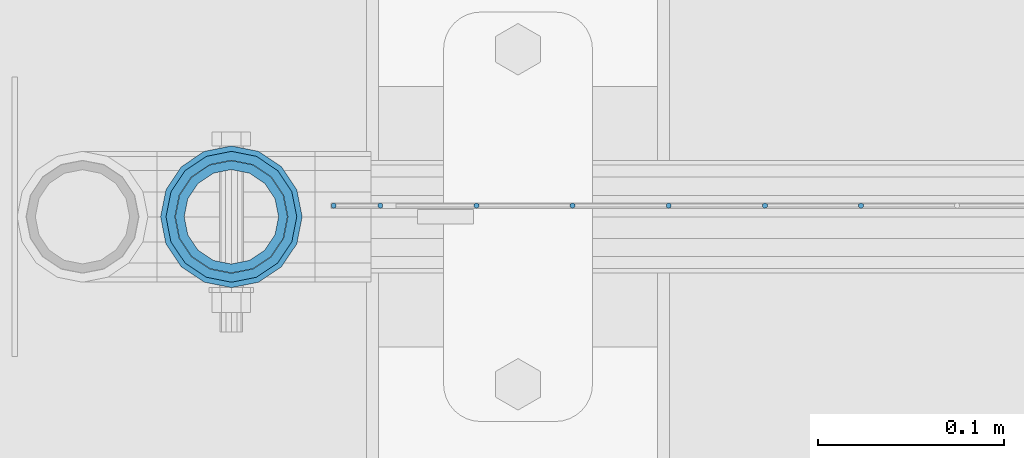
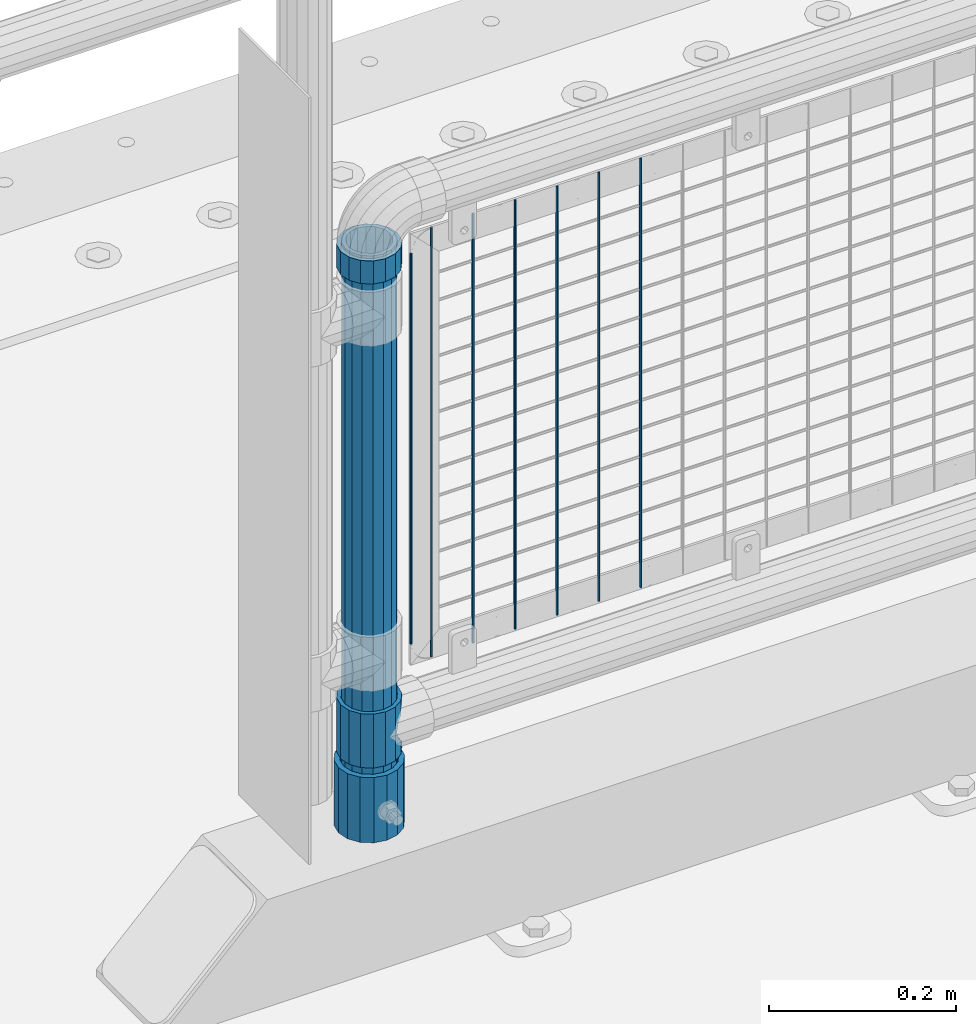
# One storey, part 52 of 193: 11 columns.
"""IFC2X3 building model written with IfcOpenShell, lengths in millimetres."""

from ifc_helpers import new_model, si_unit, frame, origin_with_axes, place, context, subcontext, project, spatial, faceted_brep, material, type_object, element, save


model = new_model("IFC2X3")

# Units and contexts
model_context = context("Model", 3, precision=1e-05, world=origin_with_axes())
body_context = subcontext(model_context, "Body", "Model", "MODEL_VIEW")
ifc_project = project(units=[si_unit("LENGTHUNIT", "METRE", prefix="MILLI"), si_unit("AREAUNIT", "SQUARE_METRE"), si_unit("VOLUMEUNIT", "CUBIC_METRE"), si_unit("MASSUNIT", "GRAM", prefix="KILO"), si_unit("TIMEUNIT", "SECOND"), si_unit("PLANEANGLEUNIT", "RADIAN"), si_unit("SOLIDANGLEUNIT", "STERADIAN"), si_unit("THERMODYNAMICTEMPERATUREUNIT", "DEGREE_CELSIUS"), si_unit("LUMINOUSINTENSITYUNIT", "LUMEN")], contexts=[model_context])

# Site, building, storey
site_placement = place(None, origin_with_axes())
site = spatial("IfcSite", under=ifc_project, at=site_placement, CompositionType="ELEMENT")
building_placement = place(site_placement, origin_with_axes())
building = spatial("IfcBuilding", under=site, at=building_placement, Name="Standard", CompositionType="ELEMENT")
storey_placement = place(building_placement, origin_with_axes())
storey = spatial("IfcBuildingStorey", under=building, at=storey_placement, Name="Undefined", CompositionType="ELEMENT", Elevation=0.0)

# Columns
ifc_material_1 = material(Name="Misc_Undefined")
column_type_1 = type_object("IfcColumnType", PredefinedType="NOTDEFINED")
column_1_placement = place(storey_placement, frame((-41829.0, 28664.5, 263.52), z_axis=(-1.0, 0.0, 0.0), x_axis=(0.0, 0.0, 1.0)))
element("IfcColumn", 1, at=column_1_placement, inside=storey, type_object=column_type_1, material=ifc_material_1, context=body_context, shape_type="Brep", body=[
    faceted_brep([(56.6106908090114, 21.46069080901, -21.46069080901), (56.6106908090114, 21.46069080901, -27.1226768591041), (61.9623795176744, 13.4513226476338, -32.4743655677703), (63.1897438117172, 11.614442172282, -32.8397438117245), (63.1897438117172, 11.614442172282, -28.0397438117179), (46.7644421722801, 28.0397438117179, -11.614442172282), (46.7644421722801, 28.0397438117179, -20.0882031229849), (51.5310424080006, 24.8548033587067, -24.8548033587067), (35.1500000000015, 30.35, 0.0), (35.1499999999996, 30.3499999999985, -16.6306603983685), (23.5355578277192, 28.0397438117179, -11.614442172282), (23.5355578277192, 28.0397438117179, -20.0882031229849), (13.6893091909879, 21.46069080901, -21.46069080901), (13.6893091909879, 21.46069080901, -27.1226768591041), (18.7689575919987, 24.8548033587067, -24.8548033587067), (7.11025618828211, 11.614442172282, -28.0397438117179), (7.11025618828211, 11.614442172282, -32.8397438117245), (8.33762048232262, 13.4513226476338, -32.4743655677703), (4.79999999999961, 0.0, -30.3499999999985), (4.79999999999961, 0.0, -35.1500000000015), (7.11025618828211, -11.614442172282, -28.0397438117179), (7.11025618828211, -11.614442172282, -32.8397438117172), (13.6893091909879, -21.46069080901, -21.46069080901), (13.6893091909879, -21.46069080901, -27.1226768591114), (8.33762048232484, -13.4513226476338, -32.4743655677703), (23.5355578277191, -28.0397438117179, -11.614442172282), (23.5355578277191, -28.0397438117179, -20.0882031229812), (18.7689575919921, -24.8548033587067, -24.8548033587067), (35.1500000000015, -30.35, 0.0), (35.1499999999996, -30.3499999999985, -16.6306603983721), (46.7644421722801, -28.0397438117179, -11.614442172282), (46.7644421722801, -28.0397438117179, -20.0882031229812), (56.6106908090114, -21.46069080901, -21.46069080901), (56.6106908090114, -21.46069080901, -27.1226768591114), (51.5310424080006, -24.8548033587067, -24.8548033587067), (63.1897438117172, -11.614442172282, -28.0397438117179), (63.1897438117172, -11.614442172282, -32.8397438117172), (61.9623795176767, -13.4513226476338, -32.4743655677703), (65.4999999999997, 0.0, -30.3499999999985), (65.4999999999997, 0.0, -35.1500000000015), (70.2999999999993, -11.614442172282, -28.0397438117179), (70.2999999999993, 0.0, -30.3499999999985), (70.2999999999993, -21.46069080901, -21.46069080901), (70.2999999999993, -28.0397438117179, -11.614442172282), (70.2999999999993, -30.3499999999985, 0.0), (0.0, -28.0397438117179, -11.614442172282), (0.0, -30.3499999999985, 0.0), (0.0, -21.46069080901, -21.46069080901), (0.0, -11.614442172282, -28.0397438117179), (0.0, 0.0, -30.3499999999985), (0.0, 11.614442172282, -28.0397438117179), (0.0, 21.46069080901, -21.46069080901), (0.0, 28.0397438117179, -11.614442172282), (0.0, 30.3499999999985, 0.0), (0.0, -24.8548033587067, -24.8548033587067), (0.0, -13.4513226476338, -32.4743655677703), (0.0, 0.0, -35.1500000000015), (0.0, 13.4513226476338, -32.4743655677703), (0.0, 24.8548033587067, -24.8548033587067), (0.0, -32.4743655677703, 13.4513226476338), (0.0, -35.1500000000015, 0.0), (70.2999999999993, -35.1500000000015, 0.0), (70.2999999999993, -32.4743655677703, 13.4513226476338), (0.0, -24.8548033587067, 24.8548033587067), (70.2999999999993, -24.8548033587067, 24.8548033587067), (0.0, -13.4513226476338, 32.4743655677703), (70.2999999999993, -13.4513226476338, 32.4743655677703), (0.0, 0.0, 35.1500000000015), (70.2999999999993, 0.0, 35.1500000000015), (0.0, 13.4513226476338, 32.4743655677703), (70.2999999999993, 13.4513226476338, 32.4743655677703), (0.0, 24.8548033587067, 24.8548033587067), (70.2999999999993, 24.8548033587067, 24.8548033587067), (0.0, 32.4743655677703, 13.4513226476338), (70.2999999999993, 32.4743655677703, 13.4513226476338), (0.0, 35.1500000000015, 0.0), (70.2999999999993, 35.1500000000015, 0.0), (0.0, 32.4743655677703, -13.4513226476338), (70.2999999999993, 32.4743655677703, -13.4513226476338), (70.2999999999993, 24.8548033587067, -24.8548033587067), (70.2999999999993, 13.4513226476338, -32.4743655677703), (70.2999999999993, 0.0, -35.1500000000015), (70.2999999999993, -13.4513226476338, -32.4743655677703), (70.2999999999993, -24.8548033587067, -24.8548033587067), (70.2999999999993, -32.4743655677703, -13.4513226476338), (0.0, -32.4743655677703, -13.4513226476338), (0.0, 28.0397438117179, 11.614442172282), (0.0, 21.46069080901, 21.46069080901), (0.0, 11.614442172282, 28.0397438117179), (0.0, 0.0, 30.3499999999985), (0.0, -11.614442172282, 28.0397438117179), (0.0, -21.46069080901, 21.46069080901), (0.0, -28.0397438117179, 11.614442172282), (70.2999999999993, 28.0397438117179, 11.614442172282), (70.2999999999993, 21.46069080901, 21.46069080901), (70.2999999999993, 11.614442172282, 28.0397438117179), (70.2999999999993, 0.0, 30.3499999999985), (70.2999999999993, -11.614442172282, 28.0397438117179), (70.2999999999993, -21.46069080901, 21.46069080901), (70.2999999999993, -28.0397438117179, 11.614442172282), (70.2999999999993, 30.3499999999985, 0.0), (70.2999999999993, 28.0397438117179, -11.614442172282), (70.2999999999993, 21.46069080901, -21.46069080901), (70.2999999999993, 11.614442172282, -28.0397438117179)], [[[0, 1, 2, 3, 4]], [[5, 6, 7, 1, 0]], [[8, 9, 6, 5]], [[10, 11, 9, 8]], [[12, 13, 14, 11, 10]], [[15, 16, 17, 13, 12]], [[18, 19, 16, 15]], [[20, 21, 19, 18]], [[22, 23, 24, 21, 20]], [[25, 26, 27, 23, 22]], [[28, 29, 26, 25]], [[30, 31, 29, 28]], [[32, 33, 34, 31, 30]], [[35, 36, 37, 33, 32]], [[38, 39, 36, 35]], [[4, 3, 39, 38]], [[40, 41, 38, 35]], [[42, 40, 35, 32]], [[43, 42, 32, 30]], [[44, 43, 30, 28]], [[45, 46, 28, 25]], [[47, 45, 25, 22]], [[48, 47, 22, 20]], [[49, 48, 20, 18]], [[50, 49, 18, 15]], [[51, 50, 15, 12]], [[52, 51, 12, 10]], [[53, 52, 10, 8]], [[54, 55, 24, 23, 27]], [[55, 56, 19, 21, 24]], [[19, 56, 57, 17, 16]], [[17, 57, 58, 14, 13]], [[59, 60, 61, 62]], [[63, 59, 62, 64]], [[65, 63, 64, 66]], [[67, 65, 66, 68]], [[69, 67, 68, 70]], [[71, 69, 70, 72]], [[73, 71, 72, 74]], [[75, 73, 74, 76]], [[77, 75, 76, 78]], [[14, 58, 77, 78, 79, 7, 6, 9, 11]], [[79, 80, 2, 1, 7]], [[80, 81, 39, 3, 2]], [[37, 82, 83, 34, 33]], [[39, 81, 82, 37, 36]], [[34, 83, 84, 85, 54, 27, 26, 29, 31]], [[60, 85, 84, 61]], [[59, 63, 65, 67, 69, 71, 73, 75, 77, 58, 57, 56, 55, 54, 85, 60], [45, 47, 48, 49, 50, 51, 52, 53, 86, 87, 88, 89, 90, 91, 92, 46]], [[87, 86, 93, 94]], [[88, 87, 94, 95]], [[89, 88, 95, 96]], [[90, 89, 96, 97]], [[91, 90, 97, 98]], [[92, 91, 98, 99]], [[28, 46, 92, 99, 44]], [[83, 82, 81, 80, 79, 78, 76, 74, 72, 70, 68, 66, 64, 62, 61, 84], [98, 97, 96, 95, 94, 93, 100, 101, 102, 103, 41, 40, 42, 43, 44, 99]], [[86, 53, 8, 100, 93]], [[101, 100, 8, 5]], [[102, 101, 5, 0]], [[103, 102, 0, 4]], [[41, 103, 4, 38]]]),
])
column_2_placement = place(storey_placement, frame((-41829.0, 28664.5, 894.849999999999), z_axis=(-1.0, 0.0, 0.0), x_axis=(0.0, 0.0, 1.0)))
element("IfcColumn", 2, at=column_2_placement, inside=storey, type_object=column_type_1, material=ifc_material_1, context=body_context, shape_type="Brep", body=[
    faceted_brep([(0.0, -30.3499999999985, 0.0), (0.0, -28.0397438117179, 11.614442172282), (30.0, -28.0397438117179, 11.6144421722805), (30.0, -30.3499999999985, 0.0), (0.0, -21.46069080901, 21.46069080901), (30.0, -21.46069080901, 21.4606908090117), (0.0, -11.614442172282, 28.0397438117179), (30.0, -11.614442172282, 28.0397438117176), (0.0, 0.0, 30.3499999999985), (30.0, 0.0, 30.35), (0.0, 11.614442172282, 28.0397438117179), (30.0, 11.614442172282, 28.0397438117176), (0.0, 21.46069080901, 21.46069080901), (30.0, 21.46069080901, 21.4606908090117), (0.0, 28.0397438117179, 11.614442172282), (30.0, 28.0397438117179, 11.6144421722805), (0.0, 30.3499999999985, 0.0), (30.0, 30.3499999999985, 0.0), (0.0, 28.0397438117179, -11.614442172282), (30.0, 28.0397438117179, -11.6144421722805), (0.0, 21.46069080901, -21.46069080901), (30.0, 21.46069080901, -21.4606908090117), (0.0, 11.614442172282, -28.0397438117179), (30.0, 11.614442172282, -28.0397438117176), (0.0, 0.0, -30.3499999999985), (30.0, 0.0, -30.35), (0.0, -11.614442172282, -28.0397438117179), (30.0, -11.614442172282, -28.0397438117176), (0.0, -21.46069080901, -21.46069080901), (30.0, -21.46069080901, -21.4606908090117), (0.0, -28.0397438117179, -11.614442172282), (30.0, -28.0397438117179, -11.6144421722805), (0.0, -35.1500000000015, 0.0), (0.0, -32.4743655677703, -13.4513226476338), (30.0, -32.4743655677703, -13.4513226476329), (30.0, -35.1500000000015, 0.0), (0.0, -24.8548033587067, -24.8548033587067), (30.0, -24.8548033587067, -24.8548033587072), (0.0, -13.4513226476338, -32.4743655677703), (30.0, -13.4513226476338, -32.4743655677718), (0.0, 0.0, -35.1500000000015), (30.0, 0.0, -35.15), (0.0, 13.4513226476338, -32.4743655677703), (30.0, 13.4513226476338, -32.4743655677718), (0.0, 24.8548033587067, -24.8548033587067), (30.0, 24.8548033587067, -24.8548033587072), (0.0, 32.4743655677703, -13.4513226476338), (30.0, 32.4743655677703, -13.4513226476329), (0.0, 35.1500000000015, 0.0), (30.0, 35.1500000000015, 0.0), (0.0, 32.4743655677703, 13.4513226476338), (30.0, 32.4743655677703, 13.4513226476329), (0.0, 24.8548033587067, 24.8548033587067), (30.0, 24.8548033587067, 24.8548033587072), (0.0, 13.4513226476338, 32.4743655677703), (30.0, 13.4513226476338, 32.4743655677718), (0.0, 0.0, 35.1500000000015), (30.0, 0.0, 35.15), (0.0, -13.4513226476338, 32.4743655677703), (30.0, -13.4513226476338, 32.4743655677718), (0.0, -24.8548033587067, 24.8548033587067), (30.0, -24.8548033587067, 24.8548033587072), (0.0, -32.4743655677703, 13.4513226476338), (30.0, -32.4743655677703, 13.4513226476329)], [[[0, 1, 2, 3]], [[1, 4, 5, 2]], [[4, 6, 7, 5]], [[6, 8, 9, 7]], [[8, 10, 11, 9]], [[10, 12, 13, 11]], [[12, 14, 15, 13]], [[14, 16, 17, 15]], [[16, 18, 19, 17]], [[18, 20, 21, 19]], [[20, 22, 23, 21]], [[22, 24, 25, 23]], [[24, 26, 27, 25]], [[26, 28, 29, 27]], [[28, 30, 31, 29]], [[30, 0, 3, 31]], [[32, 33, 34, 35]], [[33, 36, 37, 34]], [[36, 38, 39, 37]], [[38, 40, 41, 39]], [[40, 42, 43, 41]], [[42, 44, 45, 43]], [[44, 46, 47, 45]], [[46, 48, 49, 47]], [[48, 50, 51, 49]], [[50, 52, 53, 51]], [[52, 54, 55, 53]], [[54, 56, 57, 55]], [[56, 58, 59, 57]], [[58, 60, 61, 59]], [[60, 62, 63, 61]], [[62, 32, 35, 63]], [[37, 39, 41, 43, 45, 47, 49, 51, 53, 55, 57, 59, 61, 63, 35, 34], [5, 7, 9, 11, 13, 15, 17, 19, 21, 23, 25, 27, 29, 31, 3, 2]], [[62, 60, 58, 56, 54, 52, 50, 48, 46, 44, 42, 40, 38, 36, 33, 32], [30, 28, 26, 24, 22, 20, 18, 16, 14, 12, 10, 8, 6, 4, 1, 0]]]),
])
ifc_material_2 = material()
column_type_2 = type_object("IfcColumnType", PredefinedType="NOTDEFINED")
column_3_placement = place(storey_placement, frame((-41829.0000001958, 28664.5, 168.019999999998), z_axis=(-1.0, 0.0, 0.0), x_axis=(0.0, 0.0, 1.0)))
element("IfcColumn", 3, at=column_3_placement, inside=storey, type_object=column_type_2, material=ifc_material_2, context=body_context, shape_type="Brep", body=[
    faceted_brep([(0.0, -25.3499999999985, 0.0), (0.0, -23.4203461491597, 9.70102501045403), (760.0, -23.4203461491597, 9.70102501045403), (760.0, -25.3499999999985, 0.0), (0.0, -17.9251569030785, 17.9251569030785), (760.0, -17.9251569030785, 17.9251569030785), (0.0, -9.70102501045403, 23.4203461491597), (760.0, -9.70102501045403, 23.4203461491597), (0.0, 0.0, 25.3499999999985), (760.0, 0.0, 25.3499999999985), (0.0, 9.70102501045403, 23.4203461491597), (760.0, 9.70102501045403, 23.4203461491597), (0.0, 17.9251569030785, 17.9251569030785), (760.0, 17.9251569030785, 17.9251569030785), (0.0, 23.4203461491597, 9.70102501045403), (760.0, 23.4203461491597, 9.70102501045403), (0.0, 25.3499999999985, 0.0), (760.0, 25.3499999999985, 0.0), (0.0, 23.4203461491597, -9.70102501045403), (760.0, 23.4203461491597, -9.70102501045403), (0.0, 17.9251569030785, -17.9251569030785), (760.0, 17.9251569030785, -17.9251569030785), (0.0, 9.70102501045403, -23.4203461491597), (760.0, 9.70102501045403, -23.4203461491597), (0.0, 0.0, -25.3499999999985), (760.0, 0.0, -25.3499999999985), (0.0, -9.70102501045403, -23.4203461491597), (760.0, -9.70102501045403, -23.4203461491597), (0.0, -17.9251569030785, -17.9251569030785), (760.0, -17.9251569030785, -17.9251569030785), (0.0, -23.4203461491597, -9.70102501045403), (760.0, -23.4203461491597, -9.70102501045403), (0.0, -30.1500000000015, 0.0), (0.0, -27.8549679052157, -11.5379054858058), (760.0, -27.8549679052157, -11.5379054858058), (760.0, -30.1500000000015, 0.0), (0.0, -21.3192694527752, -21.3192694527752), (760.0, -21.3192694527752, -21.3192694527752), (0.0, -11.5379054858058, -27.8549679052157), (760.0, -11.5379054858058, -27.8549679052157), (0.0, 0.0, -30.1500000000015), (760.0, 0.0, -30.1500000000015), (0.0, 11.5379054858058, -27.8549679052157), (760.0, 11.5379054858058, -27.8549679052157), (0.0, 21.3192694527752, -21.3192694527752), (760.0, 21.3192694527752, -21.3192694527752), (0.0, 27.8549679052157, -11.5379054858058), (760.0, 27.8549679052157, -11.5379054858058), (0.0, 30.1500000000015, 0.0), (760.0, 30.1500000000015, 0.0), (0.0, 27.8549679052157, 11.5379054858058), (760.0, 27.8549679052157, 11.5379054858058), (0.0, 21.3192694527752, 21.3192694527752), (760.0, 21.3192694527752, 21.3192694527752), (0.0, 11.5379054858058, 27.8549679052157), (760.0, 11.5379054858058, 27.8549679052157), (0.0, 0.0, 30.1500000000015), (760.0, 0.0, 30.1500000000015), (0.0, -11.5379054858058, 27.8549679052157), (760.0, -11.5379054858058, 27.8549679052157), (0.0, -21.3192694527752, 21.3192694527752), (760.0, -21.3192694527752, 21.3192694527752), (0.0, -27.8549679052157, 11.5379054858058), (760.0, -27.8549679052157, 11.5379054858058)], [[[0, 1, 2, 3]], [[1, 4, 5, 2]], [[4, 6, 7, 5]], [[6, 8, 9, 7]], [[8, 10, 11, 9]], [[10, 12, 13, 11]], [[12, 14, 15, 13]], [[14, 16, 17, 15]], [[16, 18, 19, 17]], [[18, 20, 21, 19]], [[20, 22, 23, 21]], [[22, 24, 25, 23]], [[24, 26, 27, 25]], [[26, 28, 29, 27]], [[28, 30, 31, 29]], [[30, 0, 3, 31]], [[32, 33, 34, 35]], [[33, 36, 37, 34]], [[36, 38, 39, 37]], [[38, 40, 41, 39]], [[40, 42, 43, 41]], [[42, 44, 45, 43]], [[44, 46, 47, 45]], [[46, 48, 49, 47]], [[48, 50, 51, 49]], [[50, 52, 53, 51]], [[52, 54, 55, 53]], [[54, 56, 57, 55]], [[56, 58, 59, 57]], [[58, 60, 61, 59]], [[60, 62, 63, 61]], [[62, 32, 35, 63]], [[37, 39, 41, 43, 45, 47, 49, 51, 53, 55, 57, 59, 61, 63, 35, 34], [5, 7, 9, 11, 13, 15, 17, 19, 21, 23, 25, 27, 29, 31, 3, 2]], [[62, 60, 58, 56, 54, 52, 50, 48, 46, 44, 42, 40, 38, 36, 33, 32], [30, 28, 26, 24, 22, 20, 18, 16, 14, 12, 10, 8, 6, 4, 1, 0]]]),
])
column_type_3 = type_object("IfcColumnType", PredefinedType="NOTDEFINED")
column_4_placement = place(storey_placement, frame((-41829.0000001958, 28664.5, 168.019999999998), z_axis=(0.0, 1.0, 0.0), x_axis=(0.0, 0.0, 1.0)))
element("IfcColumn", 4, at=column_4_placement, inside=storey, type_object=column_type_3, material=ifc_material_2, context=body_context, shape_type="Brep", body=[
    faceted_brep([(0.0, -31.75, 0.0), (0.0, -29.3331751572332, 12.1501989775934), (85.0, -29.3331751572332, 12.1501989775934), (85.0, -31.75, 0.0), (0.0, -22.4506403026717, 22.4506403026717), (85.0, -22.4506403026717, 22.4506403026717), (0.0, -12.1501989775934, 29.3331751572332), (85.0, -12.1501989775934, 29.3331751572332), (0.0, 0.0, 31.75), (85.0, 0.0, 31.75), (0.0, 12.1501989775934, 29.3331751572332), (85.0, 12.1501989775934, 29.3331751572332), (0.0, 22.4506403026717, 22.4506403026717), (85.0, 22.4506403026717, 22.4506403026717), (0.0, 29.3331751572332, 12.1501989775934), (85.0, 29.3331751572332, 12.1501989775934), (0.0, 31.75, 0.0), (85.0, 31.75, 0.0), (0.0, 29.3331751572332, -12.1501989775934), (85.0, 29.3331751572332, -12.1501989775934), (0.0, 22.4506403026717, -22.4506403026717), (85.0, 22.4506403026717, -22.4506403026717), (0.0, 12.1501989775934, -29.3331751572332), (85.0, 12.1501989775934, -29.3331751572332), (0.0, 0.0, -31.75), (85.0, 0.0, -31.75), (0.0, -12.1501989775934, -29.3331751572332), (85.0, -12.1501989775934, -29.3331751572332), (0.0, -22.4506403026717, -22.4506403026717), (85.0, -22.4506403026717, -22.4506403026717), (0.0, -29.3331751572332, -12.1501989775934), (85.0, -29.3331751572332, -12.1501989775934), (0.0, -38.0499999999993, 0.0), (0.0, -35.1536162120537, -14.5611046014928), (85.0, -35.1536162120537, -14.5611046014928), (85.0, -38.0499999999993, 0.0), (0.0, -26.9054130241493, -26.9054130241493), (85.0, -26.9054130241493, -26.9054130241493), (0.0, -14.5611046014928, -35.1536162120537), (85.0, -14.5611046014928, -35.1536162120537), (0.0, 0.0, -38.0499999999993), (85.0, 0.0, -38.0499999999993), (0.0, 14.5611046014928, -35.1536162120537), (85.0, 14.5611046014928, -35.1536162120537), (0.0, 26.9054130241493, -26.9054130241493), (85.0, 26.9054130241493, -26.9054130241493), (0.0, 35.1536162120537, -14.5611046014928), (85.0, 35.1536162120537, -14.5611046014928), (0.0, 38.0499999999993, 0.0), (85.0, 38.0499999999993, 0.0), (0.0, 35.1536162120537, 14.5611046014928), (85.0, 35.1536162120537, 14.5611046014928), (0.0, 26.9054130241493, 26.9054130241493), (85.0, 26.9054130241493, 26.9054130241493), (0.0, 14.5611046014928, 35.1536162120537), (85.0, 14.5611046014928, 35.1536162120537), (0.0, 0.0, 38.0499999999993), (85.0, 0.0, 38.0499999999993), (0.0, -14.5611046014928, 35.1536162120537), (85.0, -14.5611046014928, 35.1536162120537), (0.0, -26.9054130241493, 26.9054130241493), (85.0, -26.9054130241493, 26.9054130241493), (0.0, -35.1536162120537, 14.5611046014928), (85.0, -35.1536162120537, 14.5611046014928)], [[[0, 1, 2, 3]], [[1, 4, 5, 2]], [[4, 6, 7, 5]], [[6, 8, 9, 7]], [[8, 10, 11, 9]], [[10, 12, 13, 11]], [[12, 14, 15, 13]], [[14, 16, 17, 15]], [[16, 18, 19, 17]], [[18, 20, 21, 19]], [[20, 22, 23, 21]], [[22, 24, 25, 23]], [[24, 26, 27, 25]], [[26, 28, 29, 27]], [[28, 30, 31, 29]], [[30, 0, 3, 31]], [[32, 33, 34, 35]], [[33, 36, 37, 34]], [[36, 38, 39, 37]], [[38, 40, 41, 39]], [[40, 42, 43, 41]], [[42, 44, 45, 43]], [[44, 46, 47, 45]], [[46, 48, 49, 47]], [[48, 50, 51, 49]], [[50, 52, 53, 51]], [[52, 54, 55, 53]], [[54, 56, 57, 55]], [[56, 58, 59, 57]], [[58, 60, 61, 59]], [[60, 62, 63, 61]], [[62, 32, 35, 63]], [[37, 39, 41, 43, 45, 47, 49, 51, 53, 55, 57, 59, 61, 63, 35, 34], [5, 7, 9, 11, 13, 15, 17, 19, 21, 23, 25, 27, 29, 31, 3, 2]], [[62, 60, 58, 56, 54, 52, 50, 48, 46, 44, 42, 40, 38, 36, 33, 32], [30, 28, 26, 24, 22, 20, 18, 16, 14, 12, 10, 8, 6, 4, 1, 0]]]),
])
column_type_4 = type_object("IfcColumnType", Name="D3", PredefinedType="NOTDEFINED")
for number, where, z_axis, x_axis in (
    (5, (-41490.725, 28670.5, 353.02), (-1.0, 0.0, 0.0), (0.0, 0.0, 1.0)),
    (6, (-41542.38, 28670.5, 353.02), (-1.0, 0.0, 0.0), (0.0, 0.0, 1.0)),
    (7, (-41594.035, 28670.5, 353.02), (-1.0, 0.0, 0.0), (0.0, 0.0, 1.0)),
    (8, (-41645.69, 28670.5, 353.02), (-1.0, 0.0, 0.0), (0.0, 0.0, 1.0)),
    (9, (-41697.345, 28670.5, 353.02), (-1.0, 0.0, 0.0), (0.0, 0.0, 1.0)),
):
    element("IfcColumn", number, at=place(storey_placement, frame(where, z_axis=z_axis, x_axis=x_axis)), inside=storey, type_object=column_type_4, material=ifc_material_1, ObjectType="D3", context=body_context, shape_type="Brep", body=[
        faceted_brep([(0.0, -1.49999999999636, 3.63797880709171e-12), (0.0, -0.75, -1.29903810567669), (560.0, -0.75, -1.29903810567703), (560.0, -1.5, 0.0), (0.0, 0.75, -1.29903810567669), (560.0, 0.75, -1.29903810567703), (0.0, 1.50000000000364, 7.27595761418343e-12), (560.0, 1.5, 0.0), (0.0, 0.75, 1.29903810567669), (560.0, 0.75, 1.29903810567703), (0.0, -0.75, 1.29903810567669), (560.0, -0.75, 1.29903810567703)], [[[0, 1, 2, 3]], [[1, 4, 5, 2]], [[4, 6, 7, 5]], [[6, 8, 9, 7]], [[8, 10, 11, 9]], [[10, 0, 3, 11]], [[5, 7, 9, 11, 3, 2]], [[10, 8, 6, 4, 1, 0]]]),
    ])
column_5_placement = place(storey_placement, frame((-41774.0, 28670.5, 378.02), z_axis=(-1.0, 0.0, 0.0), x_axis=(0.0, 0.0, 1.0)))
element("IfcColumn", 10, at=column_5_placement, inside=storey, type_object=column_type_4, material=ifc_material_1, ObjectType="D3", context=body_context, shape_type="Brep", body=[
    faceted_brep([(0.0, -1.49999999999636, 3.63797880709171e-12), (0.0, -0.75, -1.29903810567669), (510.0, -0.75, -1.29903810567703), (510.0, -1.5, 0.0), (0.0, 0.75, -1.29903810567669), (510.0, 0.75, -1.29903810567703), (0.0, 1.50000000000364, 7.27595761418343e-12), (510.0, 1.5, 0.0), (0.0, 0.75, 1.29903810567669), (510.0, 0.75, 1.29903810567703), (0.0, -0.75, 1.29903810567669), (510.0, -0.75, 1.29903810567703)], [[[0, 1, 2, 3]], [[1, 4, 5, 2]], [[4, 6, 7, 5]], [[6, 8, 9, 7]], [[8, 10, 11, 9]], [[10, 0, 3, 11]], [[5, 7, 9, 11, 3, 2]], [[10, 8, 6, 4, 1, 0]]]),
])
column_6_placement = place(storey_placement, frame((-41749.0, 28670.5, 353.02), z_axis=(-1.0, 0.0, 0.0), x_axis=(0.0, 0.0, 1.0)))
element("IfcColumn", 11, at=column_6_placement, inside=storey, type_object=column_type_4, material=ifc_material_1, ObjectType="D3", context=body_context, shape_type="Brep", body=[
    faceted_brep([(0.0, -1.49999999999636, 3.63797880709171e-12), (0.0, -0.75, -1.29903810567669), (560.0, -0.75, -1.29903810567703), (560.0, -1.5, 0.0), (0.0, 0.75, -1.29903810567669), (560.0, 0.75, -1.29903810567703), (0.0, 1.50000000000364, 7.27595761418343e-12), (560.0, 1.5, 0.0), (0.0, 0.75, 1.29903810567669), (560.0, 0.75, 1.29903810567703), (0.0, -0.75, 1.29903810567669), (560.0, -0.75, 1.29903810567703)], [[[0, 1, 2, 3]], [[1, 4, 5, 2]], [[4, 6, 7, 5]], [[6, 8, 9, 7]], [[8, 10, 11, 9]], [[10, 0, 3, 11]], [[5, 7, 9, 11, 3, 2]], [[10, 8, 6, 4, 1, 0]]]),
])

save(model, "model.ifc")
